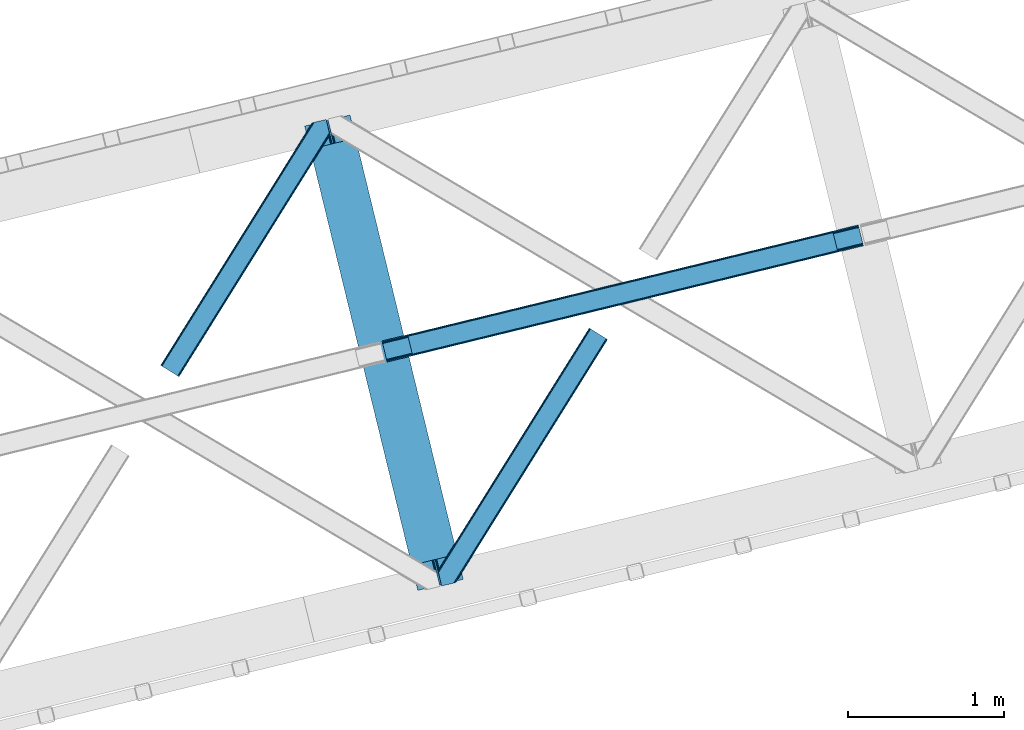
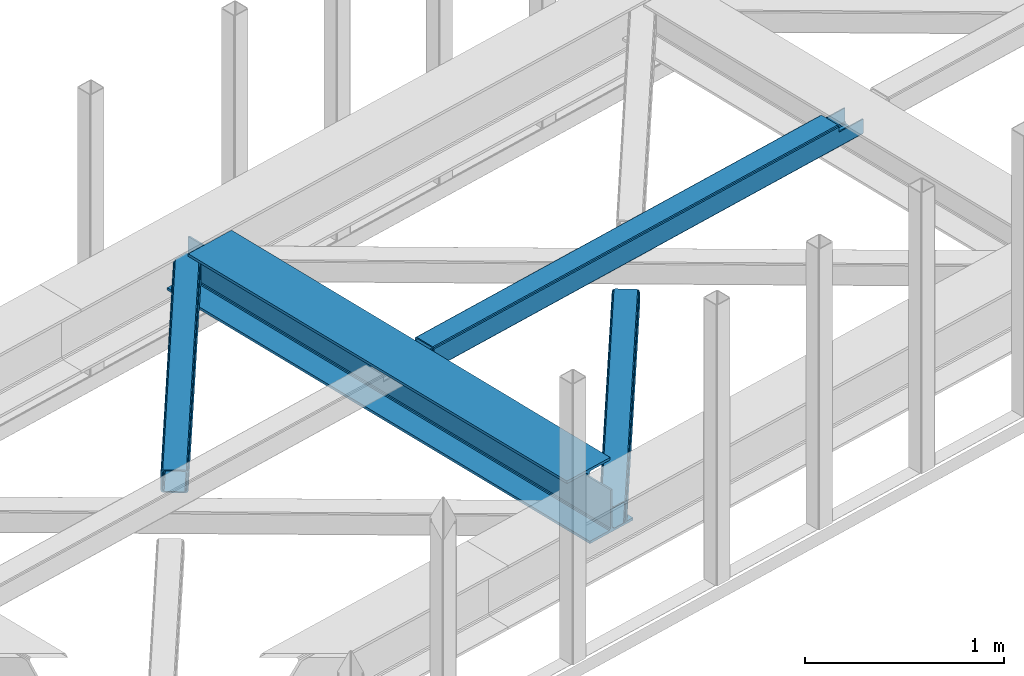
# One storey, part 44 of 67: 2 beams, 2 members.
"""IFC4 building model written with IfcOpenShell, lengths in millimetres."""

from ifc_helpers import new_model, entity, si_unit, converted_unit, derived_unit, direction, frame, origin, place, context, subcontext, project, spatial, triangles, polygons, material, type_object, element, save


model = new_model("IFC4")

# Units and contexts
model_context = context("Model", 3, precision=0.01, world=origin(), true_north=direction((6.12303176911189e-17, 1.0)))
plan_context = context("Plan", 3, precision=0.01, world=origin(), true_north=direction((6.12303176911189e-17, 1.0)))
body_context = subcontext(model_context, "Body", "Model", "MODEL_VIEW")
ifc_project = project(units=[si_unit("LENGTHUNIT", "METRE", prefix="MILLI"), si_unit("AREAUNIT", "SQUARE_METRE"), si_unit("VOLUMEUNIT", "CUBIC_METRE"), converted_unit("PLANEANGLEUNIT", "DEGREE", entity("IfcRatioMeasure", 0.0174532925199433), si_unit("PLANEANGLEUNIT", "RADIAN"), dimensions=[0, 0, 0, 0, 0, 0, 0]), si_unit("MASSUNIT", "GRAM", prefix="KILO"), derived_unit("MASSDENSITYUNIT", [(si_unit("MASSUNIT", "GRAM", prefix="KILO"), 1), (si_unit("LENGTHUNIT", "METRE"), -3)]), derived_unit("MOMENTOFINERTIAUNIT", [(si_unit("LENGTHUNIT", "METRE"), 4)]), si_unit("TIMEUNIT", "SECOND"), si_unit("FREQUENCYUNIT", "HERTZ"), si_unit("THERMODYNAMICTEMPERATUREUNIT", "DEGREE_CELSIUS"), derived_unit("THERMALTRANSMITTANCEUNIT", [(si_unit("MASSUNIT", "GRAM", prefix="KILO"), 1), (si_unit("THERMODYNAMICTEMPERATUREUNIT", "KELVIN"), -1), (si_unit("TIMEUNIT", "SECOND"), -3)]), derived_unit("VOLUMETRICFLOWRATEUNIT", [(si_unit("LENGTHUNIT", "METRE"), 3), (si_unit("TIMEUNIT", "SECOND"), -1)]), derived_unit("MASSFLOWRATEUNIT", [(si_unit("MASSUNIT", "GRAM", prefix="KILO"), 1), (si_unit("TIMEUNIT", "SECOND"), -1)]), derived_unit("ROTATIONALFREQUENCYUNIT", [(si_unit("TIMEUNIT", "SECOND"), -1)]), si_unit("ELECTRICCURRENTUNIT", "AMPERE"), si_unit("ELECTRICVOLTAGEUNIT", "VOLT"), si_unit("POWERUNIT", "WATT"), si_unit("FORCEUNIT", "NEWTON", prefix="KILO"), si_unit("ILLUMINANCEUNIT", "LUX"), si_unit("LUMINOUSFLUXUNIT", "LUMEN"), si_unit("LUMINOUSINTENSITYUNIT", "CANDELA"), derived_unit("USERDEFINED", [(si_unit("MASSUNIT", "GRAM", prefix="KILO"), -1), (si_unit("LENGTHUNIT", "METRE"), -2), (si_unit("TIMEUNIT", "SECOND"), 3), (si_unit("LUMINOUSFLUXUNIT", "LUMEN"), 1)]), derived_unit("LINEARVELOCITYUNIT", [(si_unit("LENGTHUNIT", "METRE"), 1), (si_unit("TIMEUNIT", "SECOND"), -1)]), si_unit("PRESSUREUNIT", "PASCAL"), derived_unit("USERDEFINED", [(si_unit("LENGTHUNIT", "METRE"), -2), (si_unit("MASSUNIT", "GRAM", prefix="KILO"), 1), (si_unit("TIMEUNIT", "SECOND"), -2)]), derived_unit("LINEARFORCEUNIT", [(si_unit("MASSUNIT", "GRAM", prefix="KILO"), 1), (si_unit("LENGTHUNIT", "METRE"), 1), (si_unit("TIMEUNIT", "SECOND"), -2), (si_unit("LENGTHUNIT", "METRE"), -1)]), derived_unit("PLANARFORCEUNIT", [(si_unit("MASSUNIT", "GRAM", prefix="KILO"), 1), (si_unit("LENGTHUNIT", "METRE"), 1), (si_unit("TIMEUNIT", "SECOND"), -2), (si_unit("LENGTHUNIT", "METRE"), -2)])], contexts=[model_context, plan_context])

# Site, building, storey
site_placement = place(None, origin())
site = spatial("IfcSite", under=ifc_project, at=site_placement, CompositionType="ELEMENT")
building_placement = place(site_placement, origin())
building = spatial("IfcBuilding", under=site, at=building_placement, CompositionType="ELEMENT")
storey_placement = place(building_placement, frame((0.0, 0.0, 19800.0)))
storey = spatial("IfcBuildingStorey", under=building, at=storey_placement, CompositionType="ELEMENT", Elevation=19800.0)

# Beams
ifc_material = material(Name="Metal painted (White)")
beam_type = type_object("IfcBeamType", PredefinedType="BEAM")
beam_1_placement = place(storey_placement, frame((-21094.7161386319, 12652.8689761588, 3807.02022389142)))
element("IfcBeam", 1, at=beam_1_placement, inside=storey, type_object=beam_type, material=ifc_material, ObjectType="Steel Beam", PredefinedType="BEAM", context=body_context, shape_type="Tessellation", body=[
    polygons([(1018.1664837833, 71.0478278971, 15.5000000000008), (1018.1664837833, 71.0478278971, 0.0), (291.465617442451, 3052.25531830422, 0.0), (291.465617442451, 3052.25531830421, 15.5000000000008), (894.779372399325, 40.970914087327, 15.5000000000008), (168.078506058478, 3022.17840449444, 15.5000000000008), (888.087028625379, 39.3395844888243, 16.8701684147984), (161.386162284533, 3020.54707489594, 16.8701684147984), (882.413533524764, 37.9566100336519, 20.7720779386434), (155.712667183908, 3019.16410044077, 20.7720779386434), (878.62262529618, 37.0325360459184, 26.6116982174294), (151.921758955329, 3018.24002645303, 26.6116982174294), (877.291435352788, 36.7080444135051, 33.5000000000054), (150.590569011941, 3017.91553482062, 33.5000000000054), (140.875048430527, 3015.54727389071, 33.500000000001), (140.875048430522, 3015.54727389071, 259.000000000002), (150.590569011941, 3017.91553482062, 259.000000000002), (8.66293703438714e-12, 2981.20749040711, 0.0), (4.33146851719357e-12, 2981.20749040711, 15.4999999999965), (123.387111383985, 3011.28440421689, 15.5000000000008), (130.079455157931, 3012.91573381539, 16.8701684147941), (135.752950258555, 3014.29870827056, 20.7720779386434), (139.543858487126, 3015.2227822583, 26.6116982174294), (877.291435352788, 36.7080444135051, 259.000000000002), (867.575914771373, 34.3397834835992, 259.000000000002), (867.575914771373, 34.3397834835992, 33.500000000001), (866.244724827977, 34.0152918511859, 26.6116982174294), (862.453816599402, 33.0912178634524, 20.7720779386434), (856.780321498777, 31.70824340828, 16.8701684147941), (850.087977724832, 30.0769138097752, 15.5000000000008), (726.700866340851, 2.16573425859679e-12, 15.4999999999965), (726.70086634086, 2.16573425859679e-12, 0.0), (838.124523615925, 197.385937999181, 259.069791973884), (186.46972209998, 2870.72539801218, 259.000000000002), (186.693115201833, 2869.80895360721, 259.617303331124), (186.705504045459, 2869.75812937344, 266.500003008253), (837.979344808156, 197.981416001704, 266.500002998871), (837.979694928912, 197.97997969697, 260.000004007589), (828.499586345876, 194.645865944432, 259.006343171919), (828.276216326115, 195.562317481911, 259.617303331124), (828.263827482481, 195.613141715687, 266.500003008253), (176.989986719788, 2867.38985508742, 266.500002998871), (176.989636599036, 2867.39129139215, 260.000004007589), (176.844830940692, 2867.98534020594, 259.07612046749), (176.754201518557, 2868.35713708228, 259.000000000002), (839.310832678079, 198.30468544639, 273.388305639783), (843.101109266775, 199.231350618306, 279.227924098781), (848.774180214305, 200.616065081981, 283.129832400619), (855.466371895434, 202.248018612794, 284.500000377224), (978.853400583278, 232.325271667903, 284.500000138971), (978.851730776626, 232.332121736637, 299.999995328161), (687.38630867936, 161.283492472596, 299.999995890962), (687.387978486003, 161.276642403863, 284.500000701776), (810.77500717386, 191.353895458976, 284.500000463519), (817.467494069995, 192.984637925553, 283.129832461069), (823.141405718764, 194.365903570081, 279.227924137322), (826.932940505747, 195.287407219375, 273.388305663684), (175.658498849865, 2867.06658564273, 273.388305639783), (171.868222261178, 2866.13992047082, 279.227924098781), (166.195151313635, 2864.75520600714, 283.129832400619), (159.50295963251, 2863.12325247633, 284.500000377228), (36.115930944662, 2833.04599942122, 284.500000138971), (36.1176007513137, 2833.03914935249, 299.999995328161), (327.583022848584, 2904.08777861653, 299.999995890962), (327.581353041937, 2904.09462868526, 284.500000701776), (204.194324354084, 2874.01737563015, 284.500000463519), (197.50183745795, 2872.38663316357, 283.129832461069), (191.827925809189, 2871.00536751905, 279.227924137322), (188.036391022193, 2870.08386386975, 273.388305663684)], [[[1, 2, 3, 4]], [[5, 1, 4, 6]], [[7, 5, 6, 8]], [[9, 7, 8, 10]], [[11, 9, 10, 12]], [[13, 11, 12, 14]], [[15, 16, 17, 14, 12, 10, 8, 6, 4, 3, 18, 19, 20, 21, 22, 23]], [[13, 24, 25, 26, 27, 28, 29, 30, 31, 32, 2, 1, 5, 7, 9, 11]], [[2, 32, 18, 3]], [[32, 31, 19, 18]], [[31, 30, 20, 19]], [[27, 26, 15, 23]], [[28, 27, 23, 22]], [[29, 28, 22, 21]], [[30, 29, 21, 20]], [[33, 24, 13, 14, 17, 34, 35, 36, 37, 38]], [[25, 39, 40, 41, 42, 43, 44, 16, 15, 26]], [[39, 25, 24, 33]], [[45, 34, 17, 16]], [[41, 40, 38, 37, 46, 47, 48, 49, 50, 51, 52, 53, 54, 55, 56, 57]], [[42, 58, 59, 60, 61, 62, 63, 64, 65, 66, 67, 68, 69, 36, 35, 43]], [[46, 37, 36, 69]], [[47, 46, 69, 68]], [[48, 47, 68, 67]], [[49, 48, 67, 66]], [[50, 49, 66, 65]], [[51, 50, 65, 64]], [[52, 51, 64, 63]], [[53, 52, 63, 62]], [[54, 53, 62, 61]], [[55, 54, 61, 60]], [[56, 55, 60, 59]], [[57, 56, 59, 58]], [[41, 57, 58, 42]]], closed=False),
])
beam_2_placement = place(storey_placement, frame((-20597.9799870284, 14118.9669241914, 3967.02022389142)))
element("IfcBeam", 2, at=beam_2_placement, inside=storey, type_object=beam_type, material=ifc_material, ObjectType="Steel Beam", PredefinedType="BEAM", context=body_context, shape_type="Tessellation", body=[
    polygons([(31.1823923917744, 8.09507685195891, 17.8030399336114), (31.4978703677317, 6.80086440699434, 24.4999999999988), (3089.94374939708, 752.32940514057, 24.4999999999988), (3089.62827142112, 753.623617585539, 17.8030399336114), (30.2839871259208, 11.7806820741864, 12.1256313292298), (3088.72986615526, 757.309222807767, 12.1256313292298), (28.9394286278364, 17.2965800886753, 8.33210818105214), (3087.38530765718, 762.825120822251, 8.33210818105214), (27.3534137404035, 23.8030254244661, 7.00000000000274), (3085.79929276975, 769.331566158044, 7.00000000000274), (4.21622439084993, 118.720708051131, 8.33210818105214), (5.80223927828289, 112.214262715343, 7.00000000000274), (3064.24811830763, 857.742803448919, 7.00000000000274), (3062.66210342019, 864.249248784709, 8.33210818105214), (2.87166589276557, 124.23660606562, 12.1256313292342), (3061.31754492211, 869.765146799198, 12.1256313292342), (1.97326062691193, 127.922211287848, 17.8030399336114), (3060.41913965626, 873.450752021424, 17.8030399336114), (1.65778265095034, 129.216423732819, 24.4999999999988), (3060.1036616803, 874.744964466399, 24.4999999999988), (33.1556530186647, 2.16573425859679e-12, 17.5000000000004), (33.1556530186604, 2.16573425859679e-12, 99.499999999999), (31.4978703677317, 6.80086440699001, 99.499999999999), (1.65778265094601, 129.216423732814, 99.499999999999), (1.29944055515807e-11, 136.017288139804, 99.499999999999), (2.16573425859679e-11, 136.017288139807, 17.5000000000004), (0.315477975978911, 134.723075694836, 10.803039933613), (1.21388324183255, 131.037470472612, 5.12563132923143), (2.55844173991691, 125.521572458124, 1.33210818105373), (4.14445662734987, 119.015127122331, 0.0), (29.0111963913365, 17.0021610174739, 0.0), (30.5972112787694, 10.4957156816853, 1.33210818105373), (31.9417697768538, 4.97981766719418, 5.12563132923576), (32.8401750427074, 1.29421244496891, 10.803039933613), (3058.44587902937, 881.545828873387, 17.5000000000004), (3058.44587902937, 881.545828873387, 99.499999999999), (3060.1036616803, 874.744964466399, 99.499999999999), (3089.94374939709, 752.32940514057, 99.499999999999), (3091.60153204802, 745.528540733578, 99.499999999999), (3091.60153204802, 745.528540733582, 17.5000000000004), (3091.28605407206, 746.822753178549, 10.803039933613), (3090.38764880621, 750.508358400774, 5.12563132923576), (3089.04309030813, 756.024256415266, 1.33210818105373), (3087.45707542069, 762.530701751054, 0.0), (3062.5903356567, 864.543667855911, 0.0), (3061.00432076927, 871.050113191704, 1.33210818105373), (3059.65976227119, 876.566011206193, 5.12563132923143), (3058.76135700534, 880.25161642842, 10.803039933613), (2925.75994180942, 712.30786554088, 115.5000123926), (2925.81630989429, 712.321604759494, 100.117303289864), (2926.7230036293, 712.542621518191, 99.499999999999), (194.718606580801, 46.5876811586714, 99.5063429816656), (195.631369831912, 46.8101414944987, 100.117301735448), (195.690168193631, 46.8244741223546, 115.5), (2928.38078628023, 705.741757111199, 99.499999999999), (2927.47422618798, 705.520772937689, 100.117303484932), (2927.41464342031, 705.506249905349, 122.500007895425), (197.345360928052, 40.0229783796023, 122.500002534479), (197.338587096736, 40.0213271441479, 100.500009163303), (196.748205195729, 39.8773799905065, 99.5697919021647), (2896.88292546721, 834.958147714709, 99.5063429816656), (2895.97381660774, 834.736577551993, 100.117299778624), (2895.91744852287, 834.722838333379, 115.50000888136), (165.85008047685, 169.240033448181, 115.5), (165.840462203338, 169.237688832039, 100.50000941238), (165.250325295046, 169.093836777331, 99.5761204674868), (2894.85332685228, 841.668448882876, 99.5697919021647), (163.220745767773, 175.80407176218, 99.499999999999), (164.13324493851, 176.026503182394, 100.117301984524), (164.189439987628, 176.040201208961, 122.500002796667), (2894.25631754637, 841.522886341458, 122.500003994045), (2894.26642083519, 841.525349756024, 100.500018741102), (2894.56843170075, 840.227853719296, 129.196959150505), (2895.46176722634, 836.541012377602, 134.874360354937), (2896.8030582304, 831.024317672797, 138.667878733795), (2898.38810531641, 824.517636364722, 139.999985502214), (2923.25885436334, 722.505647815407, 139.999991354279), (2924.84634848092, 715.999563150007, 138.667885332354), (2926.19460804136, 710.484567539777, 134.874367586349), (2927.09837274857, 706.800269072825, 129.196966804773), (2925.44675217773, 713.602635936897, 122.196975799125), (2924.54298747051, 717.286934403852, 127.874376580702), (2923.19472791008, 722.801930014077, 131.667894326702), (2921.60723379249, 729.30801467948, 133.000000348631), (2900.05258461849, 817.718404755552, 132.999995276841), (2898.46753753248, 824.225086063627, 131.667888508414), (2897.12624652842, 829.741780768432, 127.874370129564), (2896.23291100283, 833.428622110126, 122.196968925133), (164.878528418706, 169.00320735519, 99.499999999999), (193.131726453736, 57.3201898040356, 131.667891818946), (191.545711566299, 63.8266351398307, 133.0), (194.476284951816, 51.8042917895488, 127.874368670764), (195.37469021767, 48.1186865673235, 122.196960066391), (169.994537104178, 152.237872430705, 133.0), (166.165558452807, 167.94582100321, 122.196960066391), (167.063963718661, 164.260215780987, 127.874368670764), (168.408522216745, 158.744317766498, 131.667891818946), (197.031411944069, 41.3175635421116, 129.196961104604), (196.136488323061, 45.0040174738959, 134.874366301861), (194.79424415731, 50.5204796458708, 138.667887185257), (193.209023953578, 57.0271186991972, 139.999994588639), (168.341882306932, 159.039986838386, 139.999994981919), (166.755021471185, 165.546225960032, 138.667887628704), (165.408105180726, 171.061549222925, 134.874366787843), (164.506189230956, 174.746298656822, 129.196961619)], [[[1, 2, 3, 4]], [[5, 1, 4, 6]], [[7, 5, 6, 8]], [[9, 7, 8, 10]], [[11, 12, 13, 14]], [[15, 11, 14, 16]], [[17, 15, 16, 18]], [[19, 17, 18, 20]], [[12, 9, 10, 13]], [[21, 22, 23, 2, 1, 5, 7, 9, 12, 11, 15, 17, 19, 24, 25, 26, 27, 28, 29, 30, 31, 32, 33, 34]], [[35, 36, 37, 20, 18, 16, 14, 13, 10, 8, 6, 4, 3, 38, 39, 40, 41, 42, 43, 44, 45, 46, 47, 48]], [[49, 50, 51, 38, 3, 2, 23, 52, 53, 54]], [[55, 39, 38, 51]], [[39, 55, 56, 57, 58, 59, 60, 22, 21, 40]], [[32, 31, 44, 43]], [[33, 32, 43, 42]], [[34, 33, 42, 41]], [[21, 34, 41, 40]], [[31, 30, 45, 44]], [[27, 26, 35, 48]], [[28, 27, 48, 47]], [[29, 28, 47, 46]], [[30, 29, 46, 45]], [[20, 37, 61, 62, 63, 64, 65, 66, 24, 19]], [[67, 36, 35, 26, 25, 68, 69, 70, 71, 72]], [[36, 67, 61, 37]], [[72, 71, 73, 74, 75, 76, 77, 78, 79, 80, 57, 56, 50, 49, 81, 82, 83, 84, 85, 86, 87, 88, 63, 62]], [[60, 52, 23, 22]], [[25, 24, 89, 68]], [[90, 91, 84, 83]], [[92, 90, 83, 82]], [[93, 92, 82, 81]], [[54, 93, 81, 49]], [[94, 85, 84, 91]], [[95, 64, 63, 88]], [[96, 95, 88, 87]], [[97, 96, 87, 86]], [[94, 97, 86, 85]], [[65, 64, 95, 96, 97, 94, 91, 90, 92, 93, 54, 53, 59, 58, 98, 99, 100, 101, 102, 103, 104, 105, 70, 69]], [[98, 58, 57, 80]], [[99, 98, 80, 79]], [[100, 99, 79, 78]], [[101, 100, 78, 77]], [[77, 76, 102, 101]], [[103, 102, 76, 75]], [[104, 103, 75, 74]], [[105, 104, 74, 73]], [[70, 105, 73, 71]]], closed=False),
])

# Members
member_type_1 = type_object("IfcMemberType", PredefinedType="BRACE")
member_1_placement = place(storey_placement, frame((-22019.9512756348, 14024.2276977539, 3822.99993896484)))
element("IfcMember", 3, at=member_1_placement, inside=storey, type_object=member_type_1, ObjectType="Steel Horizontal Brace", PredefinedType="BRACE", context=body_context, shape_type="Tessellation", body=[
    triangles([(933.019793701169, 1535.69230957031, 0.0), (967.778137207031, 1393.09171142578, 0.0), (14.843280029294, 64.8692962646492, 0.0), (103.912261962891, 9.26687622070313, 0.0), (928.801446533202, 1552.99125366211, 5.49966430664063), (928.943298339844, 1552.41570739746, 5.208984375), (930.801324462889, 1544.78710327148, 1.33247680664135), (971.996484374999, 1375.79276733399, 5.49966430664063), (971.856958007811, 1376.36715087891, 5.208984375), (969.996606445311, 1383.99691772461, 1.33247680664135), (972.20577392578, 1375.53696899414, 5.8531311035149), (972.422039794921, 1375.28349609375, 6.20659790039281), (928.910742187498, 1553.56912536621, 5.74383544921875), (972.724346923827, 1375.53813171387, 6.35310058593677), (929.024688720703, 1554.17606506348, 5.9996337890625), (973.024328613279, 1375.79276733399, 6.49960327148438), (929.145611572265, 1554.78416748047, 6.25543212890625), (929.252581787106, 1555.36203918457, 6.49960327148438), (4.34624633788917, 71.4223846435561, 5.12526855468968), (1.12783813476563, 73.4304016113292, 10.8039916992202), (973.359191894531, 1630.84231567383, 10.8039916992202), (976.914788818358, 1631.70970458984, 6.49960327148438), (9.1622314453125, 68.4155914306648, 1.33247680664135), (971.505816650388, 1630.39118041992, 17.5012573242202), (0.0, 74.1361724853523, 17.5012573242202), (1081.09912719726, 1548.91708374024, 6.49960327148438), (1056.20762329101, 1651.03759460449, 6.49960327148438), (971.505816650388, 1630.39118041992, 122.499499511719), (0.0, 74.1361724853523, 122.499499511719), (973.359191894531, 1630.84231567383, 129.196765136719), (1.12783813476563, 73.4304016113292, 129.196765136719), (978.630963134765, 1632.12828369141, 134.87548828125), (4.34624633788917, 71.4223846435561, 134.87548828125), (986.525830078124, 1634.05258483887, 138.668280029298), (9.1622314453125, 68.4155914306648, 138.668280029298), (995.83921508789, 1636.32221374512, 140.00075683594), (14.843280029294, 64.8692962646492, 140.00075683594), (118.757867431639, 0.0, 17.5012573242202), (117.627703857419, 0.704608154297603, 10.8039916992202), (1085.1407409668, 1551.25066223145, 10.9783996582046), (1087.41502075195, 1552.56453552246, 13.4991760253906), (109.593310546872, 5.7205810546875, 1.33247680664135), (114.409295654295, 2.71378784179797, 5.12526855468968), (1087.56849975586, 1551.93550415039, 17.5012573242202), (1081.77583007812, 1575.70149536133, 140.00075683594), (1063.00720825195, 1652.69563293457, 140.00075683594), (103.912261962891, 9.26687622070313, 140.00075683594), (1083.99197387695, 1566.60670166016, 138.668280029298), (109.593310546872, 5.7205810546875, 138.668280029298), (1085.87092895508, 1558.89670715332, 134.87548828125), (114.409295654295, 2.71378784179797, 134.87548828125), (1087.12666625976, 1553.74469604492, 129.196765136719), (117.627703857419, 0.704608154297603, 129.196765136719), (1087.56849975586, 1551.93550415039, 122.499499511719), (118.757867431639, 0.0, 122.499499511719), (1082.53392333984, 1566.77297058106, 12.1248413085959), (1083.96406860351, 1566.72413635254, 13.4991760253906), (1077.85048828125, 1569.98556518555, 8.3320495605476), (1074.64370727539, 1577.50022277832, 6.99957275390625), (1056.69131469727, 1651.1561920166, 6.99957275390625), (1005.57117919922, 1638.69532470703, 6.99957275390625), (20.7824523925774, 61.1625457763676, 6.99957275390625), (97.9777404785127, 12.974789428712, 6.99957275390625), (108.474774169921, 6.42170104980505, 12.1248413085959), (111.693182373045, 4.41252136230469, 17.8035644531265), (1084.81052856445, 1563.2510925293, 17.8035644531265), (103.658789062498, 9.42733154296911, 8.3320495605476), (1085.25236206055, 1561.44190063477, 24.5008300781265), (112.82102050781, 3.70675048828161, 24.5008300781265), (983.091156005859, 1633.21542663574, 17.8035644531265), (981.24010620117, 1632.76429138184, 24.5008300781265), (7.06701049804542, 69.7248138427749, 17.8035644531265), (5.93917236327979, 70.430584716798, 24.5008300781265), (988.365252685544, 1634.50023193359, 12.1248413085959), (10.285418701169, 67.7156341552745, 12.1248413085959), (996.257794189452, 1636.42453308106, 8.3320495605476), (15.1014038085923, 64.7088409423832, 8.3320495605476), (981.24010620117, 1632.76429138184, 115.499926757813), (5.93917236327979, 70.430584716798, 115.499926757813), (996.257794189452, 1636.42453308106, 131.668707275392), (1005.57117919922, 1638.69532470703, 133.001184082033), (1063.00720825195, 1652.69563293457, 133.001184082033), (988.365252685544, 1634.50023193359, 127.873590087893), (983.091156005859, 1633.21542663574, 122.197192382813), (20.7824523925774, 61.1625457763676, 133.001184082033), (15.1014038085923, 64.7088409423832, 131.668707275392), (10.285418701169, 67.7156341552745, 127.873590087893), (7.06701049804542, 69.7248138427749, 122.197192382813), (108.474774169921, 6.42170104980505, 127.873590087893), (111.693182373045, 4.41252136230469, 122.197192382813), (112.82102050781, 3.70675048828161, 115.499926757813), (97.9777404785127, 12.974789428712, 133.001184082033), (103.658789062498, 9.42733154296911, 131.668707275392), (1085.25236206055, 1561.44190063477, 115.499926757813), (1084.81052856445, 1563.2510925293, 122.197192382813), (1083.55479125976, 1568.4031036377, 127.873590087893), (1081.67583618164, 1576.11309814453, 131.668707275392), (1079.45736694336, 1585.2078918457, 133.001184082033)], [[1, 2, 3], [4, 3, 2], [1, 5, 2], [6, 5, 1], [1, 7, 6], [2, 5, 8], [8, 9, 2], [10, 2, 9], [11, 8, 5], [12, 11, 13], [14, 12, 15], [16, 14, 17], [17, 18, 16], [15, 17, 14], [13, 15, 12], [5, 13, 11], [17, 19, 18], [19, 17, 15], [13, 19, 15], [19, 13, 5], [5, 6, 19], [20, 21, 18], [18, 19, 20], [21, 22, 18], [19, 6, 7], [7, 1, 23], [3, 23, 1], [7, 23, 19], [24, 21, 20], [20, 25, 24], [18, 26, 16], [26, 18, 22], [27, 26, 22], [28, 24, 25], [25, 29, 28], [30, 28, 31], [29, 31, 28], [32, 30, 33], [31, 33, 30], [34, 32, 35], [33, 35, 32], [36, 34, 37], [35, 37, 34], [38, 39, 40], [40, 41, 38], [42, 10, 9], [39, 12, 16], [16, 40, 39], [16, 26, 40], [9, 39, 43], [9, 12, 39], [9, 43, 42], [2, 10, 4], [42, 4, 10], [41, 44, 38], [45, 36, 37], [36, 45, 46], [37, 47, 45], [48, 45, 47], [47, 49, 48], [50, 48, 49], [49, 51, 50], [52, 50, 51], [51, 53, 52], [54, 52, 53], [53, 55, 54], [44, 54, 38], [55, 38, 54], [56, 40, 26], [41, 40, 56], [56, 57, 41], [58, 26, 59], [26, 58, 56], [60, 59, 26], [59, 61, 62], [61, 59, 60], [62, 63, 59], [64, 65, 66], [66, 57, 64], [58, 59, 63], [63, 67, 58], [56, 58, 67], [67, 64, 56], [57, 56, 64], [68, 66, 65], [65, 69, 68], [70, 71, 72], [73, 72, 71], [74, 70, 75], [72, 75, 70], [76, 74, 77], [75, 77, 74], [61, 76, 62], [77, 62, 76], [71, 78, 79], [79, 73, 71], [34, 36, 80], [46, 81, 36], [81, 46, 82], [81, 80, 36], [83, 34, 80], [83, 32, 34], [32, 84, 30], [84, 32, 83], [28, 84, 78], [84, 28, 30], [61, 22, 76], [70, 74, 22], [74, 76, 22], [61, 60, 22], [71, 70, 24], [21, 24, 70], [28, 71, 24], [71, 28, 78], [70, 22, 21], [80, 81, 85], [85, 86, 80], [83, 80, 86], [86, 87, 83], [84, 83, 87], [87, 88, 84], [78, 84, 88], [88, 79, 78], [53, 89, 90], [91, 38, 55], [53, 90, 55], [53, 51, 89], [90, 91, 55], [89, 51, 49], [92, 47, 37], [47, 93, 49], [93, 47, 92], [93, 89, 49], [39, 64, 43], [69, 38, 91], [38, 65, 39], [65, 38, 69], [39, 65, 64], [4, 63, 3], [42, 43, 64], [64, 67, 42], [67, 63, 4], [4, 42, 67], [87, 35, 33], [37, 85, 92], [37, 86, 85], [86, 37, 35], [87, 86, 35], [79, 29, 25], [31, 88, 87], [33, 31, 87], [88, 31, 29], [79, 88, 29], [23, 75, 19], [3, 63, 62], [62, 77, 3], [77, 75, 23], [23, 3, 77], [20, 19, 75], [25, 73, 79], [72, 25, 20], [25, 72, 73], [72, 20, 75], [66, 41, 57], [54, 44, 68], [44, 66, 68], [68, 94, 54], [44, 41, 66], [95, 54, 94], [52, 54, 95], [50, 95, 96], [95, 50, 52], [96, 48, 50], [97, 48, 96], [97, 98, 45], [97, 45, 48], [98, 46, 45], [98, 82, 46], [81, 98, 85], [81, 82, 98], [92, 85, 98], [95, 94, 90], [91, 90, 94], [96, 95, 89], [90, 89, 95], [97, 96, 93], [89, 93, 96], [98, 97, 92], [93, 92, 97], [94, 68, 91], [69, 91, 68]]),
])
member_type_2 = type_object("IfcMemberType", PredefinedType="BRACE")
member_2_placement = place(storey_placement, frame((-20238.8832458496, 12681.0701477051, 3822.99993896484)))
element("IfcMember", 4, at=member_2_placement, inside=storey, type_object=member_type_2, ObjectType="Steel Horizontal Brace", PredefinedType="BRACE", context=body_context, shape_type="Tessellation", body=[
    triangles([(986.150271606446, 1647.42851257324, 0.0), (1075.22041625977, 1591.8260925293, 0.0), (119.788037109374, 259.603921508789, 0.0), (154.548706054688, 117.003323364257, 0.0), (115.902227783205, 275.544808959961, 4.52065429687718), (117.571893310549, 268.698715209961, 1.33247680664135), (158.434515380861, 101.062435913085, 4.52065429687718), (156.767175292971, 107.908529663086, 1.33247680664135), (114.825549316407, 275.742471313477, 5.52059326172093), (115.130181884768, 275.922692871094, 5.35316162109302), (158.132208251955, 99.1218566894531, 5.27642211914281), (115.439465332031, 276.107565307617, 5.18107910156323), (158.236853027345, 99.7776306152336, 5.02062377929906), (158.188018798828, 99.4811370849602, 5.13457031250073), (115.54178466797, 276.166864013672, 5.12526855468968), (115.685961914063, 275.921530151367, 4.88574829101708), (158.339172363281, 100.434567260741, 4.76482543945531), (158.032214355469, 98.4928253173821, 5.52059326172093), (1085.71628723145, 1585.27300415039, 5.12526855468968), (1080.90495300293, 1588.28096008301, 1.33247680664135), (1088.93469543457, 1583.26498718262, 10.8039916992202), (114.209307861329, 21.8521545410149, 10.8039916992202), (109.470062255859, 20.6964111328125, 5.52059326172093), (1090.0695098877, 1582.56037902832, 17.5012573242202), (116.062683105469, 22.3044525146488, 17.5012573242202), (6.7507507324226, 102.618154907226, 5.52059326172093), (31.3608764648452, 1.65687561035156, 5.52059326172093), (1090.0695098877, 1582.56037902832, 122.499499511719), (116.062683105469, 22.3044525146488, 122.499499511719), (1088.93469543457, 1583.26498718262, 129.196765136719), (114.209307861329, 21.8521545410149, 129.196765136719), (1085.71628723145, 1585.27300415039, 134.87548828125), (108.935211181641, 20.5673492431633, 134.87548828125), (1080.90495300293, 1588.28096008301, 138.668280029298), (101.042669677736, 18.6430480957024, 138.668280029298), (1075.22041625977, 1591.8260925293, 140.00075683594), (91.7292846679702, 16.3722564697255, 140.00075683594), (980.470385742188, 1650.97480773926, 1.33247680664135), (975.654400634765, 1653.98160095215, 5.12526855468968), (1.68826904297021, 100.410150146485, 10.9621215820334), (972.435992431641, 1655.99078063965, 10.8039916992202), (971.306991577148, 1656.69655151367, 17.5012573242202), (0.239520263672603, 99.7776306152336, 12.5201660156272), (0.0, 100.760128784179, 17.5012573242202), (5.79266967773583, 76.992974853516, 140.00075683594), (986.150271606446, 1647.42851257324, 140.00075683594), (24.5612915039055, 0.0, 140.00075683594), (971.306991577148, 1656.69655151367, 122.499499511719), (0.0, 100.760128784179, 122.499499511719), (980.470385742188, 1650.97480773926, 138.668280029298), (3.57652587890698, 86.088931274413, 138.668280029298), (975.654400634765, 1653.98160095215, 134.87548828125), (1.69524536133031, 93.7989257812496, 134.87548828125), (972.435992431641, 1655.99078063965, 129.196765136719), (0.439508056642808, 98.9509368896488, 129.196765136719), (29.9237548828132, 1.30689697265552, 6.99957275390625), (12.1969299316406, 74.0326904296871, 6.99957275390625), (8.99479980468823, 81.5485107421864, 8.3320495605476), (3.88813476562427, 84.8111022949215, 12.5201660156272), (1069.28589477539, 1595.53400573731, 6.99957275390625), (81.9973205566421, 14.000308227538, 6.99957275390625), (992.090606689453, 1643.72176208496, 6.99957275390625), (981.593572998048, 1650.27485046387, 12.1248413085959), (978.375164794921, 1652.28403015137, 17.8035644531265), (2.75797119140771, 89.4445404052731, 17.8035644531265), (986.409558105468, 1647.2692199707, 8.3320495605476), (977.246163940432, 1652.98980102539, 24.5008300781265), (2.31613769531396, 91.2537322998051, 24.5008300781265), (977.246163940432, 1652.98980102539, 115.499926757813), (2.31613769531396, 91.2537322998051, 115.499926757813), (4.01370849609521, 84.2925292968739, 127.873590087893), (2.75797119140771, 89.4445404052731, 122.197192382813), (5.89266357422093, 76.5813720703118, 131.668707275392), (8.11113281250073, 67.4865783691403, 133.001184082033), (24.5612915039055, 0.0, 133.001184082033), (978.375164794921, 1652.28403015137, 122.197192382813), (981.593572998048, 1650.27485046387, 127.873590087893), (986.409558105468, 1647.2692199707, 131.668707275392), (992.090606689453, 1643.72176208496, 133.001184082033), (1069.28589477539, 1595.53400573731, 133.001184082033), (81.9973205566421, 14.000308227538, 133.001184082033), (1079.78176574707, 1588.9809173584, 12.1248413085959), (1083.0001739502, 1586.9717376709, 17.8035644531265), (1084.12917480469, 1586.2671295166, 24.5008300781265), (1074.96578063965, 1591.98771057129, 8.3320495605476), (1079.78176574707, 1588.9809173584, 127.873590087893), (1084.12917480469, 1586.2671295166, 115.499926757813), (1083.0001739502, 1586.9717376709, 122.197192382813), (1074.96578063965, 1591.98771057129, 131.668707275392), (91.3083801269531, 16.2699371337894, 131.668707275392), (99.2032470703125, 18.1942382812504, 127.873590087893), (104.477343750001, 19.4802062988274, 122.197192382813), (106.32839355469, 19.931341552734, 115.499926757813), (91.3083801269531, 16.2699371337894, 8.3320495605476), (104.477343750001, 19.4802062988274, 17.8035644531265), (99.2032470703125, 18.1942382812504, 12.1248413085959), (106.32839355469, 19.931341552734, 24.5008300781265)], [[1, 2, 3], [4, 3, 2], [5, 3, 4], [3, 5, 6], [4, 7, 5], [7, 4, 8], [9, 10, 11], [10, 12, 13], [13, 14, 10], [12, 15, 16], [16, 17, 12], [16, 5, 7], [7, 17, 16], [17, 13, 12], [14, 11, 10], [11, 18, 9], [19, 14, 13], [13, 20, 19], [13, 17, 20], [17, 7, 20], [7, 8, 20], [21, 22, 18], [18, 19, 21], [14, 19, 11], [18, 11, 19], [22, 23, 18], [21, 24, 25], [25, 22, 21], [2, 20, 4], [8, 4, 20], [23, 26, 18], [23, 27, 26], [9, 18, 26], [24, 28, 29], [29, 25, 24], [28, 30, 29], [31, 29, 30], [30, 32, 31], [33, 31, 32], [32, 34, 33], [35, 33, 34], [34, 36, 35], [37, 35, 36], [38, 6, 5], [5, 39, 38], [5, 15, 39], [40, 41, 9], [41, 39, 15], [42, 41, 40], [40, 43, 42], [43, 44, 42], [9, 26, 40], [38, 1, 6], [3, 6, 1], [36, 45, 37], [36, 46, 45], [45, 47, 37], [48, 42, 44], [44, 49, 48], [46, 50, 51], [51, 45, 46], [50, 52, 53], [53, 51, 50], [52, 54, 55], [55, 53, 52], [54, 48, 49], [49, 55, 54], [27, 56, 57], [26, 57, 58], [57, 26, 27], [59, 40, 26], [26, 58, 59], [43, 40, 59], [60, 57, 61], [60, 62, 57], [57, 56, 61], [63, 64, 65], [65, 59, 63], [66, 63, 59], [62, 66, 58], [58, 57, 62], [59, 58, 66], [64, 67, 68], [68, 65, 64], [67, 69, 68], [70, 68, 69], [71, 53, 72], [73, 74, 45], [74, 47, 45], [74, 75, 47], [51, 73, 45], [71, 51, 53], [71, 73, 51], [49, 68, 70], [55, 72, 53], [70, 72, 49], [72, 55, 49], [44, 68, 49], [43, 59, 65], [65, 68, 44], [44, 43, 65], [69, 76, 70], [72, 70, 76], [76, 77, 72], [71, 72, 77], [77, 78, 71], [73, 71, 78], [78, 79, 73], [74, 73, 79], [80, 74, 79], [74, 80, 81], [75, 74, 81], [21, 82, 83], [84, 28, 24], [21, 83, 24], [21, 19, 82], [83, 84, 24], [82, 19, 20], [60, 2, 1], [2, 85, 20], [85, 2, 60], [85, 82, 20], [30, 86, 32], [87, 28, 84], [28, 88, 30], [88, 28, 87], [30, 88, 86], [36, 80, 46], [34, 32, 86], [86, 89, 34], [89, 80, 36], [36, 34, 89], [63, 38, 39], [1, 62, 60], [1, 66, 62], [66, 1, 38], [63, 66, 38], [67, 42, 48], [41, 64, 63], [39, 41, 63], [64, 41, 42], [67, 64, 42], [50, 77, 52], [46, 80, 79], [79, 78, 46], [78, 77, 50], [50, 46, 78], [54, 52, 77], [48, 69, 67], [76, 48, 54], [48, 76, 69], [76, 54, 77], [35, 37, 90], [47, 81, 37], [81, 47, 75], [81, 90, 37], [91, 35, 90], [91, 33, 35], [33, 92, 31], [92, 33, 91], [29, 92, 93], [92, 29, 31], [61, 23, 94], [95, 96, 23], [96, 94, 23], [61, 27, 23], [27, 61, 56], [97, 95, 25], [22, 25, 95], [29, 97, 25], [97, 29, 93], [95, 23, 22], [80, 89, 90], [90, 81, 80], [89, 86, 91], [91, 90, 89], [86, 88, 92], [92, 91, 86], [88, 87, 93], [93, 92, 88], [87, 84, 97], [97, 93, 87], [84, 83, 97], [95, 97, 83], [83, 82, 95], [96, 95, 82], [82, 85, 96], [94, 96, 85], [85, 60, 94], [61, 94, 60]]),
])

save(model, "model.ifc")
